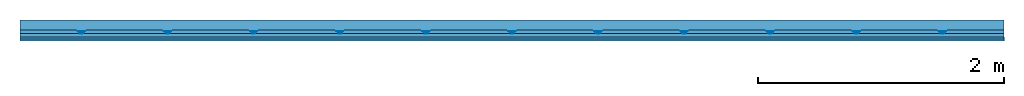
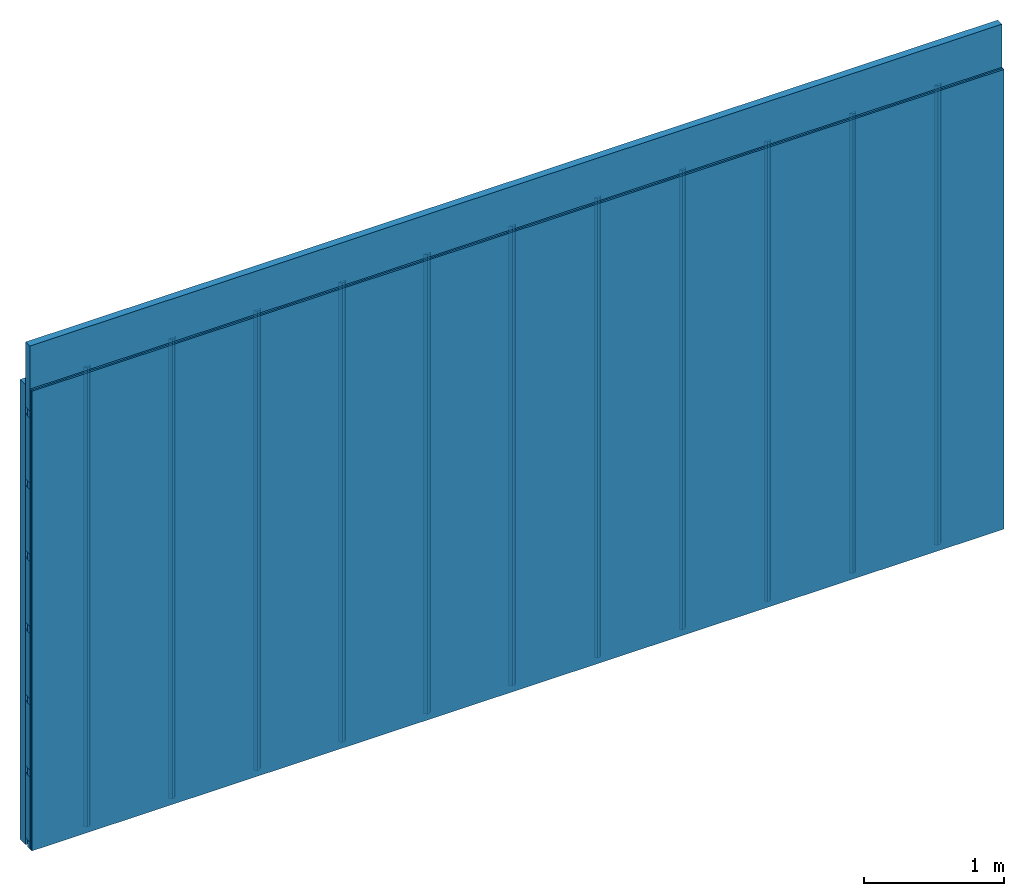
# One storey: 4 members, 2 plates, 1 element without a shape of its own.
"""IFC4 building model written with IfcOpenShell, lengths in metres."""

from ifc_helpers import new_model, si_unit, derived_unit, direction, frame, frame_2d, origin, place, context, project, spatial, polyline, rectangle, outline, extrude, material, layer, layer_set, type_object, element, aggregate, save


model = new_model("IFC4")

# Units and contexts
plan_context = context("Plan", 3, precision=1e-05, world=origin(), true_north=direction((0.0, 1.0)))
model_context = context("Model", 3, precision=1e-05, world=origin(), true_north=direction((0.0, 1.0)))
ifc_project = project(units=[si_unit("LENGTHUNIT", "METRE"), derived_unit("SOUNDPRESSUREUNIT", [(si_unit("PRESSUREUNIT", "PASCAL", prefix="MICRO"), 0)]), si_unit("ENERGYUNIT", "JOULE", prefix="MEGA"), si_unit("MASSUNIT", "GRAM", prefix="KILO"), derived_unit("THERMALTRANSMITTANCEUNIT", [(si_unit("POWERUNIT", "WATT"), 1), (si_unit("AREAUNIT", "SQUARE_METRE"), -1), (si_unit("THERMODYNAMICTEMPERATUREUNIT", "KELVIN"), -1)]), derived_unit("AREADENSITYUNIT", [(si_unit("MASSUNIT", "GRAM", prefix="KILO"), 1), (si_unit("AREAUNIT", "SQUARE_METRE"), -1)]), derived_unit("USERDEFINED", [(si_unit("ENERGYUNIT", "JOULE", prefix="MEGA"), 1), (si_unit("AREAUNIT", "SQUARE_METRE"), -1)])], contexts=[plan_context, model_context])

# Site, building, storey
site = spatial("IfcSite", under=ifc_project)
building_placement = place(None, origin())
building = spatial("IfcBuilding", under=site, at=building_placement)
storey_placement = place(building_placement, origin())
storey = spatial("IfcBuildingStorey", under=building, at=storey_placement)

# Wall, members, plates
ifc_layer_1 = layer(None, 0.08, Name="Support")
ifc_material_1 = material(Name="no composite action")
ifc_layer_2 = layer(ifc_material_1, 0.0, Name="Bond")
ifc_layer_3 = layer(None, 0.03, Name="Coupling")
ifc_layer_4 = layer(None, 0.03, Name="Battens / profiles")
ifc_material_2 = material(Category="03.007")
ifc_layer_5 = layer(ifc_material_2, 0.015, Name="Covering 1st layer")
ifc_layer_6 = layer(ifc_material_2, 0.015, Name="Covering 2nd layer")
ifc_material_3 = material(Name="Glued joints")
ifc_layer_7 = layer(ifc_material_3, 0.0, Name="Surface")
ifc_layer_set = layer_set([ifc_layer_1, ifc_layer_2, ifc_layer_3, ifc_layer_4, ifc_layer_5, ifc_layer_6, ifc_layer_7])
wall_type = type_object("IfcWallType", Name="C0105", PredefinedType="NOTDEFINED", material=ifc_layer_set)
wall_placement = place(None, frame((0.0, 0.0, 0.0), z_axis=(0.0, -1.0, 0.0), x_axis=(1.0, 0.0, 0.0)))
wall = element("IfcWall", 1, at=wall_placement, inside=storey, type_object=wall_type, material=ifc_layer_set, Name="Wall #1")
ifc_material_4 = material()
member_1_placement = place(wall_placement, origin())
member_1 = element("IfcMember", 2, at=member_1_placement, material=ifc_material_4, Name="Support", context=plan_context, shape_type="SweptSolid", body=[
    extrude(rectangle(XDim=1.0, YDim=0.08, at=frame_2d((0.5, 0.04), x_axis=(1.0, 0.0))), frame((0.0, 4.0, 0.0), z_axis=(0.0, -1.0, 0.0), x_axis=(1.0, 0.0, 0.0)), (0.0, 0.0, 1.0), 4.0),
    extrude(rectangle(XDim=1.0, YDim=0.08, at=frame_2d((0.5, 0.04), x_axis=(1.0, 0.0))), frame((1.0, 4.0, 0.0), z_axis=(0.0, -1.0, 0.0), x_axis=(1.0, 0.0, 0.0)), (0.0, 0.0, 1.0), 4.0),
    extrude(rectangle(XDim=1.0, YDim=0.08, at=frame_2d((0.5, 0.04), x_axis=(1.0, 0.0))), frame((2.0, 4.0, 0.0), z_axis=(0.0, -1.0, 0.0), x_axis=(1.0, 0.0, 0.0)), (0.0, 0.0, 1.0), 4.0),
    extrude(rectangle(XDim=1.0, YDim=0.08, at=frame_2d((0.5, 0.04), x_axis=(1.0, 0.0))), frame((3.0, 4.0, 0.0), z_axis=(0.0, -1.0, 0.0), x_axis=(1.0, 0.0, 0.0)), (0.0, 0.0, 1.0), 4.0),
    extrude(rectangle(XDim=1.0, YDim=0.08, at=frame_2d((0.5, 0.04), x_axis=(1.0, 0.0))), frame((4.0, 4.0, 0.0), z_axis=(0.0, -1.0, 0.0), x_axis=(1.0, 0.0, 0.0)), (0.0, 0.0, 1.0), 4.0),
    extrude(rectangle(XDim=1.0, YDim=0.08, at=frame_2d((0.5, 0.04), x_axis=(1.0, 0.0))), frame((5.0, 4.0, 0.0), z_axis=(0.0, -1.0, 0.0), x_axis=(1.0, 0.0, 0.0)), (0.0, 0.0, 1.0), 4.0),
    extrude(rectangle(XDim=1.0, YDim=0.08, at=frame_2d((0.5, 0.04), x_axis=(1.0, 0.0))), frame((6.0, 4.0, 0.0), z_axis=(0.0, -1.0, 0.0), x_axis=(1.0, 0.0, 0.0)), (0.0, 0.0, 1.0), 4.0),
    extrude(rectangle(XDim=1.0, YDim=0.08, at=frame_2d((0.5, 0.04), x_axis=(1.0, 0.0))), frame((7.0, 4.0, 0.0), z_axis=(0.0, -1.0, 0.0), x_axis=(1.0, 0.0, 0.0)), (0.0, 0.0, 1.0), 4.0),
])
ifc_material_5 = material()
member_2_placement = place(wall_placement, origin())
member_2 = element("IfcMember", 3, at=member_2_placement, material=ifc_material_5, Name="Coupling", context=plan_context, shape_type="SweptSolid", body=[
    extrude(outline(polyline([(0.0, 0.0), (0.06, 0.0), (0.04, 0.02), (0.02, 0.02), (0.0, 0.0)])), frame((0.47, 4.0, 0.09), z_axis=(0.0, -1.0, 0.0), x_axis=(1.0, 0.0, 0.0)), (0.0, 0.0, 1.0), 4.0),
    extrude(outline(polyline([(0.0, 0.0), (0.06, 0.0), (0.04, 0.02), (0.02, 0.02), (0.0, 0.0)])), frame((1.17, 4.0, 0.09), z_axis=(0.0, -1.0, 0.0), x_axis=(1.0, 0.0, 0.0)), (0.0, 0.0, 1.0), 4.0),
    extrude(outline(polyline([(0.0, 0.0), (0.06, 0.0), (0.04, 0.02), (0.02, 0.02), (0.0, 0.0)])), frame((1.87, 4.0, 0.09), z_axis=(0.0, -1.0, 0.0), x_axis=(1.0, 0.0, 0.0)), (0.0, 0.0, 1.0), 4.0),
    extrude(outline(polyline([(0.0, 0.0), (0.06, 0.0), (0.04, 0.02), (0.02, 0.02), (0.0, 0.0)])), frame((2.57, 4.0, 0.09), z_axis=(0.0, -1.0, 0.0), x_axis=(1.0, 0.0, 0.0)), (0.0, 0.0, 1.0), 4.0),
    extrude(outline(polyline([(0.0, 0.0), (0.06, 0.0), (0.04, 0.02), (0.02, 0.02), (0.0, 0.0)])), frame((3.27, 4.0, 0.09), z_axis=(0.0, -1.0, 0.0), x_axis=(1.0, 0.0, 0.0)), (0.0, 0.0, 1.0), 4.0),
    extrude(outline(polyline([(0.0, 0.0), (0.06, 0.0), (0.04, 0.02), (0.02, 0.02), (0.0, 0.0)])), frame((3.97, 4.0, 0.09), z_axis=(0.0, -1.0, 0.0), x_axis=(1.0, 0.0, 0.0)), (0.0, 0.0, 1.0), 4.0),
    extrude(outline(polyline([(0.0, 0.0), (0.06, 0.0), (0.04, 0.02), (0.02, 0.02), (0.0, 0.0)])), frame((4.67, 4.0, 0.09), z_axis=(0.0, -1.0, 0.0), x_axis=(1.0, 0.0, 0.0)), (0.0, 0.0, 1.0), 4.0),
    extrude(outline(polyline([(0.0, 0.0), (0.06, 0.0), (0.04, 0.02), (0.02, 0.02), (0.0, 0.0)])), frame((5.37, 4.0, 0.09), z_axis=(0.0, -1.0, 0.0), x_axis=(1.0, 0.0, 0.0)), (0.0, 0.0, 1.0), 4.0),
    extrude(outline(polyline([(0.0, 0.0), (0.06, 0.0), (0.04, 0.02), (0.02, 0.02), (0.0, 0.0)])), frame((6.07, 4.0, 0.09), z_axis=(0.0, -1.0, 0.0), x_axis=(1.0, 0.0, 0.0)), (0.0, 0.0, 1.0), 4.0),
    extrude(outline(polyline([(0.0, 0.0), (0.06, 0.0), (0.04, 0.02), (0.02, 0.02), (0.0, 0.0)])), frame((6.77, 4.0, 0.09), z_axis=(0.0, -1.0, 0.0), x_axis=(1.0, 0.0, 0.0)), (0.0, 0.0, 1.0), 4.0),
    extrude(outline(polyline([(0.0, 0.0), (0.06, 0.0), (0.04, 0.02), (0.02, 0.02), (0.0, 0.0)])), frame((7.47, 4.0, 0.09), z_axis=(0.0, -1.0, 0.0), x_axis=(1.0, 0.0, 0.0)), (0.0, 0.0, 1.0), 4.0),
])
member_3_placement = place(wall_placement, origin())
member_3 = element("IfcMember", 4, at=member_3_placement, material=ifc_material_5, Name="Battens / profiles", context=plan_context, shape_type="SweptSolid", body=[
    extrude(rectangle(XDim=0.06, YDim=0.03, at=frame_2d((0.03, 0.015), x_axis=(1.0, 0.0))), frame((0.0, 0.0, 0.11), z_axis=(1.0, 0.0, 0.0), x_axis=(0.0, 1.0, 0.0)), (0.0, 0.0, 1.0), 8.0),
    extrude(rectangle(XDim=0.06, YDim=0.03, at=frame_2d((0.03, 0.015), x_axis=(1.0, 0.0))), frame((0.0, 0.625, 0.11), z_axis=(1.0, 0.0, 0.0), x_axis=(0.0, 1.0, 0.0)), (0.0, 0.0, 1.0), 8.0),
    extrude(rectangle(XDim=0.06, YDim=0.03, at=frame_2d((0.03, 0.015), x_axis=(1.0, 0.0))), frame((0.0, 1.25, 0.11), z_axis=(1.0, 0.0, 0.0), x_axis=(0.0, 1.0, 0.0)), (0.0, 0.0, 1.0), 8.0),
    extrude(rectangle(XDim=0.06, YDim=0.03, at=frame_2d((0.03, 0.015), x_axis=(1.0, 0.0))), frame((0.0, 1.875, 0.11), z_axis=(1.0, 0.0, 0.0), x_axis=(0.0, 1.0, 0.0)), (0.0, 0.0, 1.0), 8.0),
    extrude(rectangle(XDim=0.06, YDim=0.03, at=frame_2d((0.03, 0.015), x_axis=(1.0, 0.0))), frame((0.0, 2.5, 0.11), z_axis=(1.0, 0.0, 0.0), x_axis=(0.0, 1.0, 0.0)), (0.0, 0.0, 1.0), 8.0),
    extrude(rectangle(XDim=0.06, YDim=0.03, at=frame_2d((0.03, 0.015), x_axis=(1.0, 0.0))), frame((0.0, 3.125, 0.11), z_axis=(1.0, 0.0, 0.0), x_axis=(0.0, 1.0, 0.0)), (0.0, 0.0, 1.0), 8.0),
    extrude(rectangle(XDim=0.06, YDim=0.03, at=frame_2d((0.03, 0.015), x_axis=(1.0, 0.0))), frame((0.0, 3.75, 0.11), z_axis=(1.0, 0.0, 0.0), x_axis=(0.0, 1.0, 0.0)), (0.0, 0.0, 1.0), 8.0),
])
ifc_material_6 = material()
member_4_placement = place(wall_placement, origin())
member_4 = element("IfcMember", 5, at=member_4_placement, material=ifc_material_6, Name="Cavity", context=plan_context, shape_type="SweptSolid", body=[
    extrude(rectangle(XDim=0.565, YDim=0.06, at=frame_2d((0.2825, 0.03), x_axis=(1.0, 0.0))), frame((0.0, 0.06, 0.08), z_axis=(1.0, 0.0, 0.0), x_axis=(0.0, 1.0, 0.0)), (0.0, 0.0, 1.0), 8.0),
    extrude(rectangle(XDim=0.565, YDim=0.06, at=frame_2d((0.2825, 0.03), x_axis=(1.0, 0.0))), frame((0.0, 0.685, 0.08), z_axis=(1.0, 0.0, 0.0), x_axis=(0.0, 1.0, 0.0)), (0.0, 0.0, 1.0), 8.0),
    extrude(rectangle(XDim=0.565, YDim=0.06, at=frame_2d((0.2825, 0.03), x_axis=(1.0, 0.0))), frame((0.0, 1.31, 0.08), z_axis=(1.0, 0.0, 0.0), x_axis=(0.0, 1.0, 0.0)), (0.0, 0.0, 1.0), 8.0),
    extrude(rectangle(XDim=0.565, YDim=0.06, at=frame_2d((0.2825, 0.03), x_axis=(1.0, 0.0))), frame((0.0, 1.935, 0.08), z_axis=(1.0, 0.0, 0.0), x_axis=(0.0, 1.0, 0.0)), (0.0, 0.0, 1.0), 8.0),
    extrude(rectangle(XDim=0.565, YDim=0.06, at=frame_2d((0.2825, 0.03), x_axis=(1.0, 0.0))), frame((0.0, 2.56, 0.08), z_axis=(1.0, 0.0, 0.0), x_axis=(0.0, 1.0, 0.0)), (0.0, 0.0, 1.0), 8.0),
    extrude(rectangle(XDim=0.565, YDim=0.06, at=frame_2d((0.2825, 0.03), x_axis=(1.0, 0.0))), frame((0.0, 3.185, 0.08), z_axis=(1.0, 0.0, 0.0), x_axis=(0.0, 1.0, 0.0)), (0.0, 0.0, 1.0), 8.0),
    extrude(rectangle(XDim=0.565, YDim=0.06, at=frame_2d((0.2825, 0.03), x_axis=(1.0, 0.0))), frame((0.0, 3.81, 0.08), z_axis=(1.0, 0.0, 0.0), x_axis=(0.0, 1.0, 0.0)), (0.0, 0.0, 1.0), 8.0),
])
plate_1_placement = place(wall_placement, origin())
plate_1 = element("IfcPlate", 6, at=plate_1_placement, material=ifc_material_2, Name="Covering 1st layer", context=plan_context, shape_type="SweptSolid", body=[
    extrude(rectangle(XDim=8.0, YDim=4.0, at=frame_2d((4.0, 2.0), x_axis=(1.0, 0.0))), frame((0.0, 0.0, 0.14), z_axis=(0.0, 0.0, 1.0), x_axis=(1.0, 0.0, 0.0)), (0.0, 0.0, 1.0), 0.015),
])
plate_2_placement = place(wall_placement, origin())
plate_2 = element("IfcPlate", 7, at=plate_2_placement, material=ifc_material_2, Name="Covering 2nd layer", context=plan_context, shape_type="SweptSolid", body=[
    extrude(rectangle(XDim=8.0, YDim=4.0, at=frame_2d((4.0, 2.0), x_axis=(1.0, 0.0))), frame((0.0, 0.0, 0.155), z_axis=(0.0, 0.0, 1.0), x_axis=(1.0, 0.0, 0.0)), (0.0, 0.0, 1.0), 0.015),
])
aggregate(wall, [member_1, member_2, member_3, member_4, plate_1, plate_2])

save(model, "model.ifc")
